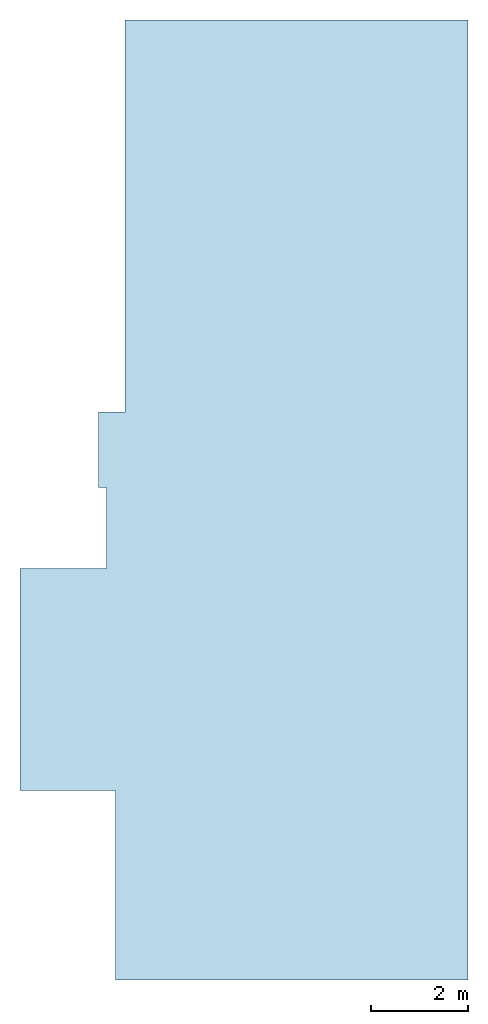
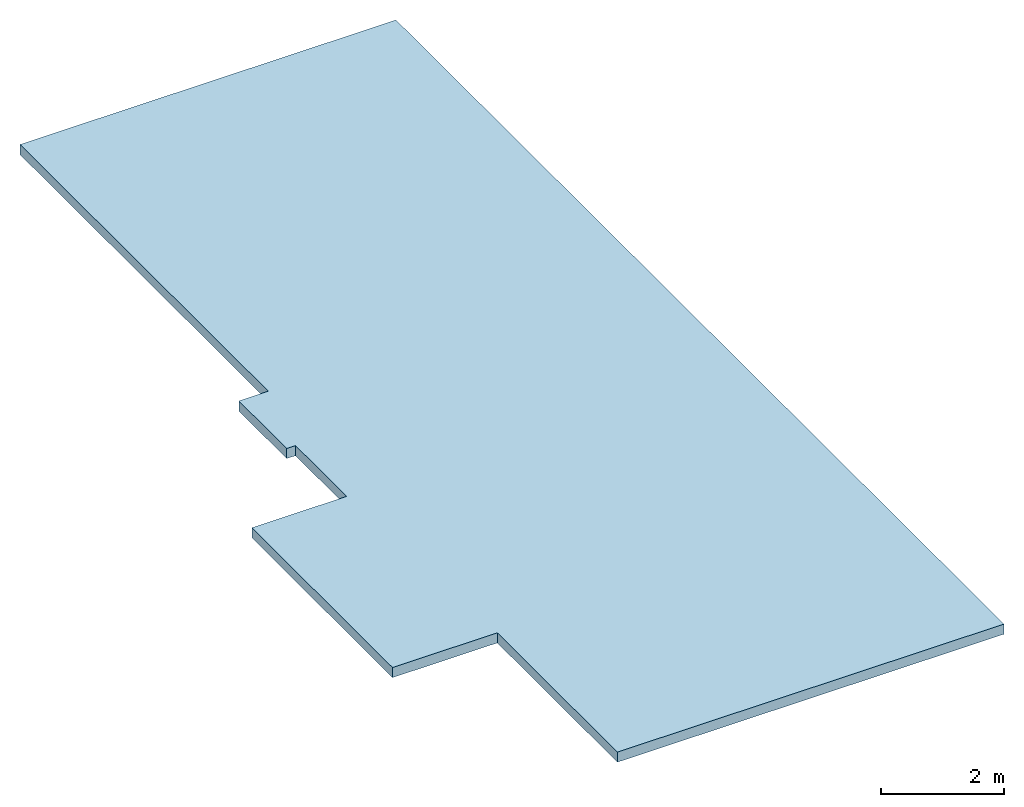
# One storey: 1 slab.
"""IFC2X3 building model written with IfcOpenShell, lengths in metres."""

from ifc_helpers import new_model, entity, si_unit, converted_unit, derived_unit, direction, frame, origin, place, context, subcontext, project, spatial, polyline, outline, extrude, material, layer, layer_set, layer_usage, type_object, element, save


model = new_model("IFC2X3")

# Units and contexts
model_context = context("Model", 3, precision=1e-05, world=origin(), true_north=direction((6.123031769111886e-17, 1.0)))
body_context = subcontext(model_context, "Body", "Model", "MODEL_VIEW")
ifc_project = project(units=[si_unit("LENGTHUNIT", "METRE"), si_unit("AREAUNIT", "SQUARE_METRE"), si_unit("VOLUMEUNIT", "CUBIC_METRE"), converted_unit("PLANEANGLEUNIT", "DEGREE", entity("IfcRatioMeasure", 0.017453292519943278), si_unit("PLANEANGLEUNIT", "RADIAN"), dimensions=[0, 0, 0, 0, 0, 0, 0]), si_unit("MASSUNIT", "GRAM", prefix="KILO"), derived_unit("MASSDENSITYUNIT", [(si_unit("MASSUNIT", "GRAM", prefix="KILO"), 1), (si_unit("LENGTHUNIT", "METRE"), -3)]), derived_unit("IONCONCENTRATIONUNIT", [(si_unit("MASSUNIT", "GRAM", prefix="KILO"), 1), (si_unit("LENGTHUNIT", "METRE"), -3)]), derived_unit("MOMENTOFINERTIAUNIT", [(si_unit("LENGTHUNIT", "METRE"), 4)]), si_unit("TIMEUNIT", "SECOND"), si_unit("FREQUENCYUNIT", "HERTZ"), si_unit("THERMODYNAMICTEMPERATUREUNIT", "DEGREE_CELSIUS"), derived_unit("THERMALTRANSMITTANCEUNIT", [(si_unit("MASSUNIT", "GRAM", prefix="KILO"), 1), (si_unit("THERMODYNAMICTEMPERATUREUNIT", "KELVIN"), -1), (si_unit("TIMEUNIT", "SECOND"), -3)]), derived_unit("THERMALCONDUCTANCEUNIT", [(si_unit("MASSUNIT", "GRAM", prefix="KILO"), 1), (si_unit("THERMODYNAMICTEMPERATUREUNIT", "KELVIN"), -1), (si_unit("TIMEUNIT", "SECOND"), -3), (si_unit("LENGTHUNIT", "METRE"), 1)]), derived_unit("VOLUMETRICFLOWRATEUNIT", [(si_unit("LENGTHUNIT", "METRE"), 3), (si_unit("TIMEUNIT", "SECOND"), -1)]), derived_unit("MASSFLOWRATEUNIT", [(si_unit("MASSUNIT", "GRAM", prefix="KILO"), 1), (si_unit("TIMEUNIT", "SECOND"), -1)]), derived_unit("ROTATIONALFREQUENCYUNIT", [(si_unit("TIMEUNIT", "SECOND"), -1)]), si_unit("ELECTRICCURRENTUNIT", "AMPERE"), si_unit("ELECTRICVOLTAGEUNIT", "VOLT"), si_unit("POWERUNIT", "WATT"), si_unit("FORCEUNIT", "NEWTON", prefix="KILO"), si_unit("ILLUMINANCEUNIT", "LUX"), si_unit("LUMINOUSFLUXUNIT", "LUMEN"), si_unit("LUMINOUSINTENSITYUNIT", "CANDELA"), derived_unit("USERDEFINED", [(si_unit("MASSUNIT", "GRAM", prefix="KILO"), -1), (si_unit("LENGTHUNIT", "METRE"), -2), (si_unit("TIMEUNIT", "SECOND"), 3), (si_unit("LUMINOUSFLUXUNIT", "LUMEN"), 1)]), derived_unit("USERDEFINED", [(si_unit("MASSUNIT", "GRAM", prefix="KILO"), 1), (si_unit("TIMEUNIT", "SECOND"), -3), (si_unit("LENGTHUNIT", "METRE"), 3), (si_unit("ELECTRICCURRENTUNIT", "AMPERE"), -2)]), derived_unit("SOUNDPOWERUNIT", [(si_unit("MASSUNIT", "GRAM", prefix="KILO"), 1), (si_unit("TIMEUNIT", "SECOND"), -3), (si_unit("LENGTHUNIT", "METRE"), 2)]), derived_unit("SOUNDPRESSUREUNIT", [(si_unit("MASSUNIT", "GRAM", prefix="KILO"), 1), (si_unit("LENGTHUNIT", "METRE"), -1), (si_unit("TIMEUNIT", "SECOND"), -2)]), derived_unit("LINEARVELOCITYUNIT", [(si_unit("LENGTHUNIT", "METRE"), 1), (si_unit("TIMEUNIT", "SECOND"), -1)]), si_unit("PRESSUREUNIT", "PASCAL"), derived_unit("USERDEFINED", [(si_unit("MASSUNIT", "GRAM", prefix="KILO"), 1), (si_unit("LENGTHUNIT", "METRE"), -2), (si_unit("TIMEUNIT", "SECOND"), -2)]), derived_unit("LINEARFORCEUNIT", [(si_unit("MASSUNIT", "GRAM", prefix="KILO"), 1), (si_unit("TIMEUNIT", "SECOND"), -2)]), derived_unit("PLANARFORCEUNIT", [(si_unit("MASSUNIT", "GRAM", prefix="KILO"), 1), (si_unit("LENGTHUNIT", "METRE"), -1), (si_unit("TIMEUNIT", "SECOND"), -2)]), derived_unit("SPECIFICHEATCAPACITYUNIT", [(si_unit("THERMODYNAMICTEMPERATUREUNIT", "KELVIN"), -1), (si_unit("LENGTHUNIT", "METRE"), 2), (si_unit("TIMEUNIT", "SECOND"), -2)]), derived_unit("HEATINGVALUEUNIT", [(si_unit("LENGTHUNIT", "METRE"), 2), (si_unit("TIMEUNIT", "SECOND"), -2)]), derived_unit("VAPORPERMEABILITYUNIT", [(si_unit("LENGTHUNIT", "METRE"), -1), (si_unit("TIMEUNIT", "SECOND"), 1)]), derived_unit("DYNAMICVISCOSITYUNIT", [(si_unit("MASSUNIT", "GRAM", prefix="KILO"), 1), (si_unit("TIMEUNIT", "SECOND"), -1), (si_unit("LENGTHUNIT", "METRE"), -1)]), derived_unit("THERMALEXPANSIONCOEFFICIENTUNIT", [(si_unit("THERMODYNAMICTEMPERATUREUNIT", "KELVIN"), -1)]), derived_unit("MODULUSOFELASTICITYUNIT", [(si_unit("MASSUNIT", "GRAM", prefix="KILO"), 1), (si_unit("LENGTHUNIT", "METRE"), -1), (si_unit("TIMEUNIT", "SECOND"), -2)]), derived_unit("ISOTHERMALMOISTURECAPACITYUNIT", [(si_unit("LENGTHUNIT", "METRE"), 3), (si_unit("MASSUNIT", "GRAM", prefix="KILO"), -1)]), derived_unit("MOISTUREDIFFUSIVITYUNIT", [(si_unit("TIMEUNIT", "SECOND"), -1), (si_unit("LENGTHUNIT", "METRE"), 2)])], contexts=[model_context])

# Site, building, storey
site_placement = place(None, origin())
site = spatial("IfcSite", under=ifc_project, at=site_placement, CompositionType="ELEMENT")
building_placement = place(site_placement, origin())
building = spatial("IfcBuilding", under=site, at=building_placement, CompositionType="ELEMENT")
storey_placement = place(building_placement, frame((0.0, 0.0, 3.3)))
storey = spatial("IfcBuildingStorey", under=building, at=storey_placement, CompositionType="ELEMENT", Elevation=3.3)

# Slab
ifc_material = material(Name="Concrete, Cast-in-Place gray")
ifc_layer = layer(ifc_material, 0.2)
ifc_layer_set = layer_set([ifc_layer], Name="Floor:Structural 200mm")
ifc_layer_usage = layer_usage(ifc_layer_set, "AXIS3", "POSITIVE", 0.0)
slab_type = type_object("IfcSlabType", Name="Floor:Structural 200mm", PredefinedType="FLOOR", material=ifc_layer_set)
slab_placement = place(storey_placement, origin())
element("IfcSlab", 1, at=slab_placement, inside=storey, type_object=slab_type, material=ifc_layer_usage, Name="Floor:Structural 200mm", ObjectType="Floor:Structural 200mm", PredefinedType="FLOOR", context=body_context, shape_type="SweptSolid", body=[
    extrude(outline(polyline([(-5.088952341900446, -2.7891565106893363), (-0.518952341900451, -2.7891565106893363), (-0.518952341900451, -1.0116565106893278), (1.1410476580995486, -1.0116565106893256), (1.1410476580995486, -1.1767174465533123), (2.6947617095023038, -1.1767174465533101), (2.6947617095022993, -0.6241565106893098), (10.761047658099532, -0.6241565106893098), (10.761047658099532, 6.425843489310651), (-8.988952341900484, 6.425843489310651), (-8.988952341900484, -0.8241565106893682), (-5.088952341900446, -0.8241565106893682), (-5.088952341900446, -2.7891565106893363)])), frame((-2.8258434893102566, 8.988952341900635, 0.2999999999999995), z_axis=(0.0, 0.0, -1.0), x_axis=(0.0, 1.0, 0.0)), (0.0, 0.0, 1.0), 0.2),
])

save(model, "model.ifc")
